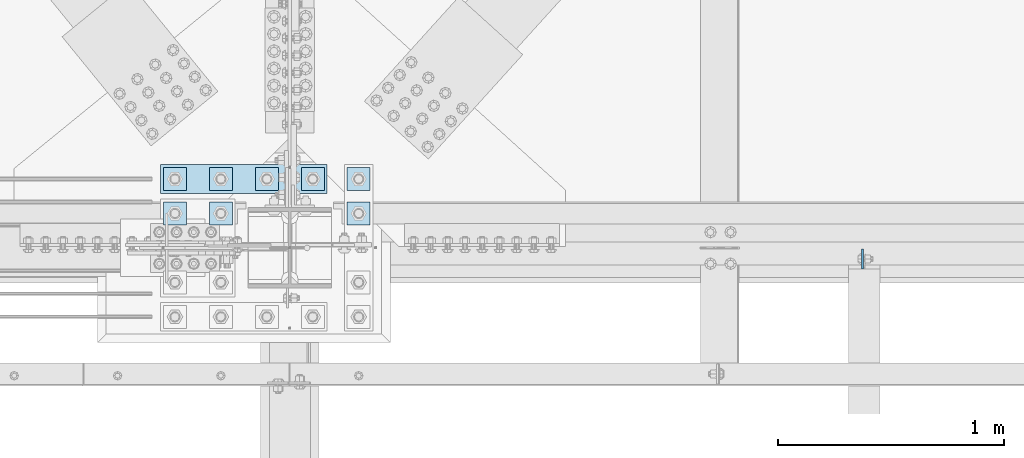
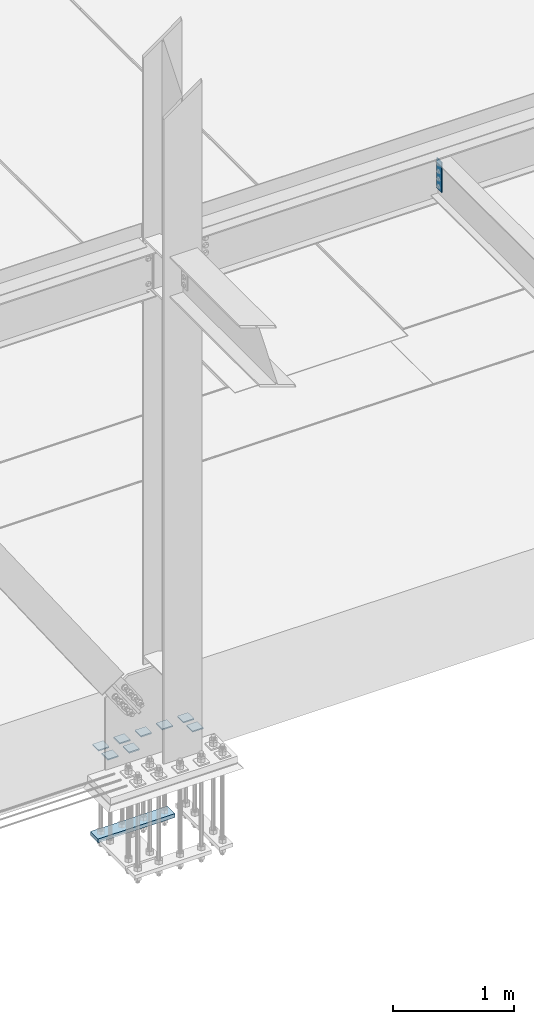
# One storey, part 3186 of 3843: 10 plates, 2 elements without a shape of their own.
"""IFC2X3 building model written with IfcOpenShell, lengths in millimetres."""

from ifc_helpers import new_model, si_unit, frame, origin_with_axes, place, context, subcontext, project, spatial, faceted_brep, material, type_object, element, aggregate, save


model = new_model("IFC2X3")

# Units and contexts
model_context = context("Model", 3, precision=1e-05, world=origin_with_axes())
body_context = subcontext(model_context, "Body", "Model", "MODEL_VIEW")
ifc_project = project(units=[si_unit("LENGTHUNIT", "METRE", prefix="MILLI"), si_unit("AREAUNIT", "SQUARE_METRE"), si_unit("VOLUMEUNIT", "CUBIC_METRE"), si_unit("MASSUNIT", "GRAM", prefix="KILO"), si_unit("TIMEUNIT", "SECOND"), si_unit("PLANEANGLEUNIT", "RADIAN"), si_unit("SOLIDANGLEUNIT", "STERADIAN"), si_unit("THERMODYNAMICTEMPERATUREUNIT", "DEGREE_CELSIUS"), si_unit("LUMINOUSINTENSITYUNIT", "LUMEN")], contexts=[model_context])

# Site, building, storey
site_placement = place(None, origin_with_axes())
site = spatial("IfcSite", under=ifc_project, at=site_placement, CompositionType="ELEMENT")
building_placement = place(site_placement, origin_with_axes())
building = spatial("IfcBuilding", under=site, at=building_placement, Name="Undefined", CompositionType="ELEMENT")
storey_placement = place(building_placement, origin_with_axes())
storey = spatial("IfcBuildingStorey", under=building, at=storey_placement, Name="Undefined", CompositionType="ELEMENT", Elevation=0.0)

# Assembly, plate
assembly_1_placement = place(storey_placement, origin_with_axes())
assembly_1 = element("IfcElementAssembly", 1, at=assembly_1_placement, inside=storey, Name="BEAM", AssemblyPlace="NOTDEFINED", PredefinedType="RIGID_FRAME")
ifc_material = material(Name="STEEL/A572-50")
plate_type_1 = type_object("IfcPlateType", PredefinedType="NOTDEFINED")
plate_1_placement = place(assembly_1_placement, frame((65168.4625, 25611.93125, 34772.6), z_axis=(0.0, -1.0, 0.0), x_axis=(0.0, 0.0, -1.0)))
plate_1 = element("IfcPlate", 2, at=plate_1_placement, type_object=plate_type_1, material=ifc_material, Name="PLATE", context=body_context, shape_type="Brep", body=[
    faceted_brep([(0.0, -4.76249999999709, 0.0), (0.0, -4.76249999999709, 88.9000015258789), (0.0, 4.76249999999709, 88.9000015258789), (0.0, 4.76249999999709, 0.0), (304.800000000003, -4.76249999999709, 88.8999999999942), (304.800000000003, 4.76249999999709, 88.8999999999942), (304.800000000003, -4.76249999999709, 0.0), (304.800000000003, 4.76249999999709, 0.0)], [[[0, 1, 2, 3]], [[1, 4, 5, 2]], [[4, 6, 7, 5]], [[6, 0, 3, 7]], [[5, 7, 3, 2]], [[6, 4, 1, 0]]]),
])
aggregate(assembly_1, [plate_1])

# Assembly, plates
assembly_2_placement = place(storey_placement, origin_with_axes())
assembly_2 = element("IfcElementAssembly", 3, at=assembly_2_placement, inside=storey, Name="TEMPLATE", AssemblyPlace="NOTDEFINED", PredefinedType="RIGID_FRAME")
plate_type_2 = type_object("IfcPlateType", PredefinedType="NOTDEFINED")
plate_2_placement = place(assembly_2_placement, frame((62179.2, 25819.1, 29686.25), z_axis=(-1.0, 0.0, 0.0), x_axis=(0.0, -1.0, 0.0)))
plate_2 = element("IfcPlate", 4, at=plate_2_placement, type_object=plate_type_2, material=ifc_material, Name="Washer Plate", context=body_context, shape_type="Brep", body=[
    faceted_brep([(0.0, -6.3499999046162, 0.0), (-1.67347025126219e-10, -6.35000000000582, 101.600000000151), (-1.67347025126219e-10, 6.35000000000582, 101.600000000151), (7.27595761418343e-12, 6.3499999046162, 0.0), (101.599998474121, -6.34999999999854, 101.599998474121), (101.599998474121, 6.34999999999854, 101.599998474121), (101.6, -6.34999999999854, 0.0), (101.6, 6.34999999999854, 0.0)], [[[0, 1, 2, 3]], [[1, 4, 5, 2]], [[4, 6, 7, 5]], [[6, 0, 3, 7]], [[5, 7, 3, 2]], [[6, 4, 1, 0]]]),
])
plate_3_placement = place(assembly_2_placement, frame((62382.4, 25819.1, 29686.25), z_axis=(-1.0, 0.0, 0.0), x_axis=(0.0, -1.0, 0.0)))
plate_3 = element("IfcPlate", 5, at=plate_3_placement, type_object=plate_type_2, material=ifc_material, Name="Washer Plate", context=body_context, shape_type="Brep", body=[
    faceted_brep([(0.0, -6.3499999046162, 0.0), (-1.67347025126219e-10, -6.35000000000582, 101.600000000151), (-1.67347025126219e-10, 6.35000000000582, 101.600000000151), (7.27595761418343e-12, 6.3499999046162, 0.0), (101.599998474121, -6.34999999999854, 101.599998474121), (101.599998474121, 6.34999999999854, 101.599998474121), (101.6, -6.34999999999854, 0.0), (101.6, 6.34999999999854, 0.0)], [[[0, 1, 2, 3]], [[1, 4, 5, 2]], [[4, 6, 7, 5]], [[6, 0, 3, 7]], [[5, 7, 3, 2]], [[6, 4, 1, 0]]]),
])
plate_4_placement = place(assembly_2_placement, frame((62992.0, 25819.1, 29686.25), z_axis=(-1.0, 0.0, 0.0), x_axis=(0.0, -1.0, 0.0)))
plate_4 = element("IfcPlate", 6, at=plate_4_placement, type_object=plate_type_2, material=ifc_material, Name="Washer Plate", context=body_context, shape_type="Brep", body=[
    faceted_brep([(0.0, -6.3499999046162, 0.0), (-1.67347025126219e-10, -6.35000000000582, 101.600000000151), (-1.67347025126219e-10, 6.35000000000582, 101.600000000151), (7.27595761418343e-12, 6.3499999046162, 0.0), (101.599998474121, -6.34999999999854, 101.599998474121), (101.599998474121, 6.34999999999854, 101.599998474121), (101.6, -6.34999999999854, 0.0), (101.6, 6.34999999999854, 0.0)], [[[0, 1, 2, 3]], [[1, 4, 5, 2]], [[4, 6, 7, 5]], [[6, 0, 3, 7]], [[5, 7, 3, 2]], [[6, 4, 1, 0]]]),
])
plate_5_placement = place(assembly_2_placement, frame((62179.2, 25971.5, 29686.25), z_axis=(-1.0, 0.0, 0.0), x_axis=(0.0, -1.0, 0.0)))
plate_5 = element("IfcPlate", 7, at=plate_5_placement, type_object=plate_type_2, material=ifc_material, Name="Washer Plate", context=body_context, shape_type="Brep", body=[
    faceted_brep([(0.0, -6.3499999046162, 0.0), (-1.67347025126219e-10, -6.35000000000582, 101.600000000151), (-1.67347025126219e-10, 6.35000000000582, 101.600000000151), (7.27595761418343e-12, 6.3499999046162, 0.0), (101.599998474121, -6.34999999999854, 101.599998474121), (101.599998474121, 6.34999999999854, 101.599998474121), (101.6, -6.34999999999854, 0.0), (101.6, 6.34999999999854, 0.0)], [[[0, 1, 2, 3]], [[1, 4, 5, 2]], [[4, 6, 7, 5]], [[6, 0, 3, 7]], [[5, 7, 3, 2]], [[6, 4, 1, 0]]]),
])
plate_6_placement = place(assembly_2_placement, frame((62382.4, 25971.5, 29686.25), z_axis=(-1.0, 0.0, 0.0), x_axis=(0.0, -1.0, 0.0)))
plate_6 = element("IfcPlate", 8, at=plate_6_placement, type_object=plate_type_2, material=ifc_material, Name="Washer Plate", context=body_context, shape_type="Brep", body=[
    faceted_brep([(0.0, -6.3499999046162, 0.0), (-1.67347025126219e-10, -6.35000000000582, 101.600000000151), (-1.67347025126219e-10, 6.35000000000582, 101.600000000151), (7.27595761418343e-12, 6.3499999046162, 0.0), (101.599998474121, -6.34999999999854, 101.599998474121), (101.599998474121, 6.34999999999854, 101.599998474121), (101.6, -6.34999999999854, 0.0), (101.6, 6.34999999999854, 0.0)], [[[0, 1, 2, 3]], [[1, 4, 5, 2]], [[4, 6, 7, 5]], [[6, 0, 3, 7]], [[5, 7, 3, 2]], [[6, 4, 1, 0]]]),
])
plate_7_placement = place(assembly_2_placement, frame((62585.6, 25971.5, 29686.25), z_axis=(-1.0, 0.0, 0.0), x_axis=(0.0, -1.0, 0.0)))
plate_7 = element("IfcPlate", 9, at=plate_7_placement, type_object=plate_type_2, material=ifc_material, Name="Washer Plate", context=body_context, shape_type="Brep", body=[
    faceted_brep([(0.0, -6.3499999046162, 0.0), (-1.67347025126219e-10, -6.35000000000582, 101.600000000151), (-1.67347025126219e-10, 6.35000000000582, 101.600000000151), (7.27595761418343e-12, 6.3499999046162, 0.0), (101.599998474121, -6.34999999999854, 101.599998474121), (101.599998474121, 6.34999999999854, 101.599998474121), (101.6, -6.34999999999854, 0.0), (101.6, 6.34999999999854, 0.0)], [[[0, 1, 2, 3]], [[1, 4, 5, 2]], [[4, 6, 7, 5]], [[6, 0, 3, 7]], [[5, 7, 3, 2]], [[6, 4, 1, 0]]]),
])
plate_8_placement = place(assembly_2_placement, frame((62788.8, 25971.5, 29686.25), z_axis=(-1.0, 0.0, 0.0), x_axis=(0.0, -1.0, 0.0)))
plate_8 = element("IfcPlate", 10, at=plate_8_placement, type_object=plate_type_2, material=ifc_material, Name="Washer Plate", context=body_context, shape_type="Brep", body=[
    faceted_brep([(0.0, -6.3499999046162, 0.0), (-1.67347025126219e-10, -6.35000000000582, 101.600000000151), (-1.67347025126219e-10, 6.35000000000582, 101.600000000151), (7.27595761418343e-12, 6.3499999046162, 0.0), (101.599998474121, -6.34999999999854, 101.599998474121), (101.599998474121, 6.34999999999854, 101.599998474121), (101.6, -6.34999999999854, 0.0), (101.6, 6.34999999999854, 0.0)], [[[0, 1, 2, 3]], [[1, 4, 5, 2]], [[4, 6, 7, 5]], [[6, 0, 3, 7]], [[5, 7, 3, 2]], [[6, 4, 1, 0]]]),
])
plate_9_placement = place(assembly_2_placement, frame((62992.0, 25971.5, 29686.25), z_axis=(-1.0, 0.0, 0.0), x_axis=(0.0, -1.0, 0.0)))
plate_9 = element("IfcPlate", 11, at=plate_9_placement, type_object=plate_type_2, material=ifc_material, Name="Washer Plate", context=body_context, shape_type="Brep", body=[
    faceted_brep([(0.0, -6.3499999046162, 0.0), (-1.67347025126219e-10, -6.35000000000582, 101.600000000151), (-1.67347025126219e-10, 6.35000000000582, 101.600000000151), (7.27595761418343e-12, 6.3499999046162, 0.0), (101.599998474121, -6.34999999999854, 101.599998474121), (101.599998474121, 6.34999999999854, 101.599998474121), (101.6, -6.34999999999854, 0.0), (101.6, 6.34999999999854, 0.0)], [[[0, 1, 2, 3]], [[1, 4, 5, 2]], [[4, 6, 7, 5]], [[6, 0, 3, 7]], [[5, 7, 3, 2]], [[6, 4, 1, 0]]]),
])
plate_type_3 = type_object("IfcPlateType", PredefinedType="NOTDEFINED")
plate_10_placement = place(assembly_2_placement, frame((62801.5, 25984.2, 28784.55), z_axis=(-1.0, 0.0, 0.0), x_axis=(0.0, -1.0, 0.0)))
plate_10 = element("IfcPlate", 12, at=plate_10_placement, type_object=plate_type_3, material=ifc_material, Name="PLATE", context=body_context, shape_type="Brep", body=[
    faceted_brep([(0.0, -19.0500000000029, 0.0), (0.0, -19.0499999999993, 736.600036621094), (0.0, 19.0499999999993, 736.600036621094), (0.0, 19.0500000000029, 0.0), (127.0, -19.0499999999993, 736.600036621094), (127.0, 19.0499999999993, 736.600036621094), (127.0, -19.0499999999993, 0.0), (127.0, 19.0499999999993, 0.0)], [[[0, 1, 2, 3]], [[1, 4, 5, 2]], [[4, 6, 7, 5]], [[6, 0, 3, 7]], [[5, 7, 3, 2]], [[6, 4, 1, 0]]]),
])
aggregate(assembly_2, [plate_2, plate_3, plate_4, plate_5, plate_6, plate_7, plate_8, plate_9, plate_10])

save(model, "model.ifc")
